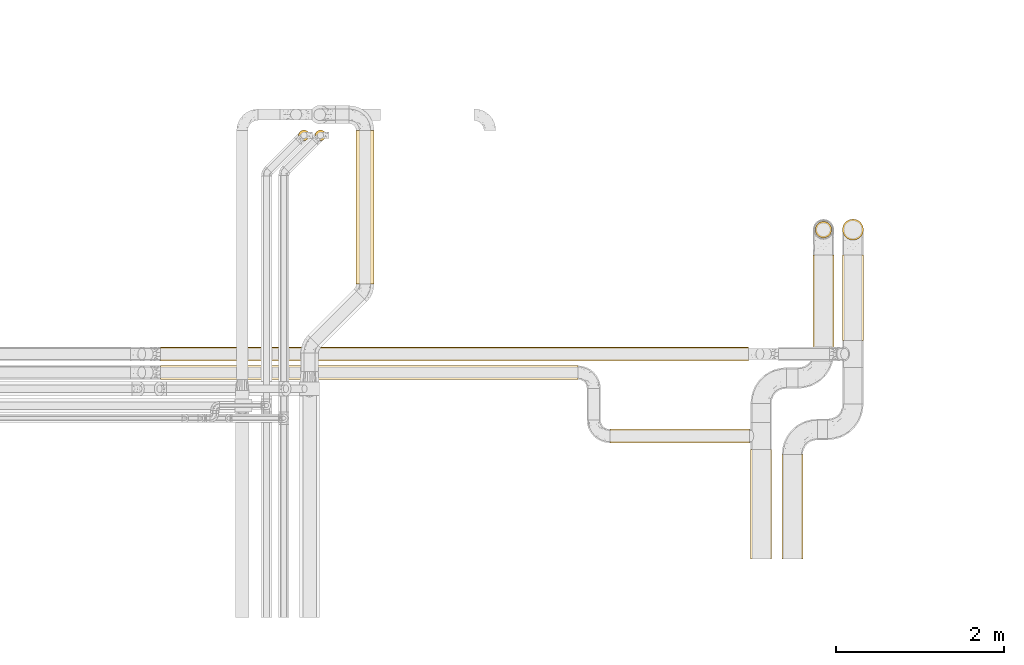
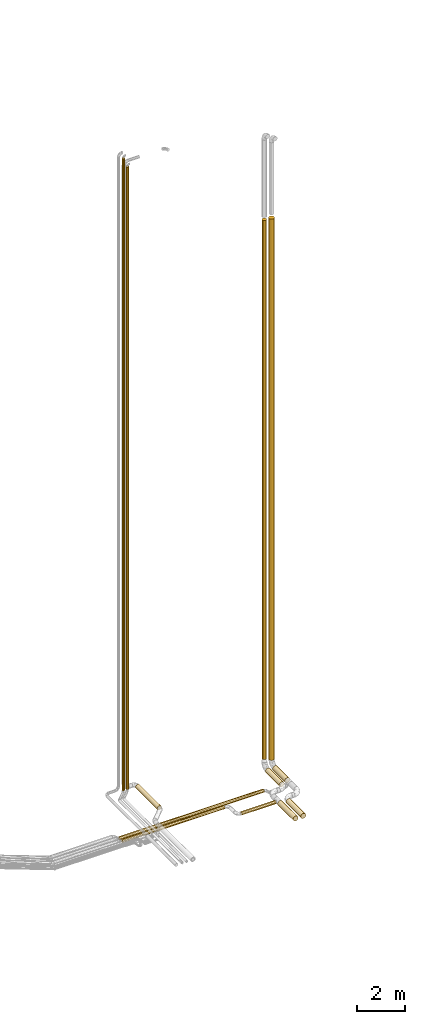
# One storey, part 2 of 93: 12 coverings.
"""IFC2X3 building model written with IfcOpenShell, lengths in millimetres."""

from ifc_helpers import new_model, entity, si_unit, converted_unit, derived_unit, direction, frame, origin, origin_2d_with_axis, place, context, subcontext, project, spatial, circle, extrude, element, save


model = new_model("IFC2X3")

# Units and contexts
model_context = context("Model", 3, precision=0.01, world=origin(), true_north=direction((6.12303176911189e-17, 1.0)))
body_context = subcontext(model_context, "Body", "Model", "MODEL_VIEW")
ifc_project = project(units=[si_unit("LENGTHUNIT", "METRE", prefix="MILLI"), si_unit("AREAUNIT", "SQUARE_METRE"), si_unit("VOLUMEUNIT", "CUBIC_METRE"), converted_unit("PLANEANGLEUNIT", "DEGREE", entity("IfcRatioMeasure", 0.0174532925199433), si_unit("PLANEANGLEUNIT", "RADIAN"), dimensions=[0, 0, 0, 0, 0, 0, 0]), si_unit("MASSUNIT", "GRAM", prefix="KILO"), derived_unit("MASSDENSITYUNIT", [(si_unit("MASSUNIT", "GRAM", prefix="KILO"), 1), (si_unit("LENGTHUNIT", "METRE"), -3)]), derived_unit("MOMENTOFINERTIAUNIT", [(si_unit("LENGTHUNIT", "METRE"), 4)]), si_unit("TIMEUNIT", "SECOND"), si_unit("FREQUENCYUNIT", "HERTZ"), si_unit("THERMODYNAMICTEMPERATUREUNIT", "DEGREE_CELSIUS"), derived_unit("THERMALTRANSMITTANCEUNIT", [(si_unit("MASSUNIT", "GRAM", prefix="KILO"), 1), (si_unit("THERMODYNAMICTEMPERATUREUNIT", "KELVIN"), -1), (si_unit("TIMEUNIT", "SECOND"), -3)]), derived_unit("VOLUMETRICFLOWRATEUNIT", [(si_unit("LENGTHUNIT", "METRE"), 3), (si_unit("TIMEUNIT", "SECOND"), -1)]), derived_unit("MASSFLOWRATEUNIT", [(si_unit("MASSUNIT", "GRAM", prefix="KILO"), 1), (si_unit("TIMEUNIT", "SECOND"), -1)]), derived_unit("ROTATIONALFREQUENCYUNIT", [(si_unit("TIMEUNIT", "SECOND"), -1)]), si_unit("ELECTRICCURRENTUNIT", "AMPERE"), si_unit("ELECTRICVOLTAGEUNIT", "VOLT"), si_unit("POWERUNIT", "WATT"), si_unit("FORCEUNIT", "NEWTON", prefix="KILO"), si_unit("ILLUMINANCEUNIT", "LUX"), si_unit("LUMINOUSFLUXUNIT", "LUMEN"), si_unit("LUMINOUSINTENSITYUNIT", "CANDELA"), derived_unit("USERDEFINED", [(si_unit("MASSUNIT", "GRAM", prefix="KILO"), -1), (si_unit("LENGTHUNIT", "METRE"), -2), (si_unit("TIMEUNIT", "SECOND"), 3), (si_unit("LUMINOUSFLUXUNIT", "LUMEN"), 1)]), derived_unit("LINEARVELOCITYUNIT", [(si_unit("LENGTHUNIT", "METRE"), 1), (si_unit("TIMEUNIT", "SECOND"), -1)]), si_unit("PRESSUREUNIT", "PASCAL"), derived_unit("USERDEFINED", [(si_unit("LENGTHUNIT", "METRE"), -2), (si_unit("MASSUNIT", "GRAM", prefix="KILO"), 1), (si_unit("TIMEUNIT", "SECOND"), -2)]), derived_unit("LINEARFORCEUNIT", [(si_unit("MASSUNIT", "GRAM", prefix="KILO"), 1), (si_unit("LENGTHUNIT", "METRE"), 1), (si_unit("TIMEUNIT", "SECOND"), -2), (si_unit("LENGTHUNIT", "METRE"), -1)]), derived_unit("PLANARFORCEUNIT", [(si_unit("MASSUNIT", "GRAM", prefix="KILO"), 1), (si_unit("LENGTHUNIT", "METRE"), 1), (si_unit("TIMEUNIT", "SECOND"), -2), (si_unit("LENGTHUNIT", "METRE"), -2)])], contexts=[model_context])

# Site, building, storey
site_placement = place(None, origin())
site = spatial("IfcSite", under=ifc_project, at=site_placement, CompositionType="ELEMENT")
building_placement = place(site_placement, origin())
building = spatial("IfcBuilding", under=site, at=building_placement, CompositionType="ELEMENT")
storey_placement = place(building_placement, frame((0.0, 0.0, -4200.0)))
storey = spatial("IfcBuildingStorey", under=building, at=storey_placement, CompositionType="ELEMENT", Elevation=-4200.0)

# Coverings
covering_1_placement = place(storey_placement, frame((25531.03, 10304.27, 2891.9)))
element("IfcCovering", 1, at=covering_1_placement, inside=storey, PredefinedType="INSULATION", context=body_context, shape_type="SweptSolid", body=[
    extrude(circle(Radius=106.5, at=origin_2d_with_axis()), frame((108.1, 0.0, 108.1), z_axis=(0.0, 1.0, 0.0), x_axis=(-1.0, 0.0, 0.0)), (0.0, 0.0, 1.0), 1821.29942314912),
])
covering_2_placement = place(storey_placement, frame((30213.69, 7038.76, 2673.9)))
element("IfcCovering", 2, at=covering_2_placement, inside=storey, PredefinedType="INSULATION", context=body_context, shape_type="SweptSolid", body=[
    extrude(circle(Radius=124.5, at=origin_2d_with_axis()), frame((126.1, 0.0, 126.1), z_axis=(0.0, 1.0, 0.0), x_axis=(-1.0, 0.0, 0.0)), (0.0, 0.0, 1.0), 1301.23958365229),
])
covering_3_placement = place(storey_placement, frame((30980.9, 10850.9, 3240.0)))
element("IfcCovering", 3, at=covering_3_placement, inside=storey, PredefinedType="INSULATION", context=body_context, shape_type="SweptSolid", body=[
    extrude(circle(Radius=97.5, at=origin_2d_with_axis()), frame((99.1, 99.1, 0.0), z_axis=(0.0, 0.0, 1.0), x_axis=(-1.0, 0.0, 0.0)), (0.0, 0.0, 1.0), 27542.5),
])
covering_4_placement = place(storey_placement, frame((24847.71, 12005.41, 3100.0)))
element("IfcCovering", 4, at=covering_4_placement, inside=storey, PredefinedType="INSULATION", context=body_context, shape_type="SweptSolid", body=[
    extrude(circle(Radius=63.0, at=origin_2d_with_axis()), frame((64.6, 64.6, 0.0), z_axis=(0.0, 0.0, 1.0), x_axis=(-1.0, 0.0, 0.0)), (0.0, 0.0, 1.0), 32300.0),
])
covering_5_placement = place(storey_placement, frame((25044.13, 12005.41, 3100.0)))
element("IfcCovering", 5, at=covering_5_placement, inside=storey, PredefinedType="INSULATION", context=body_context, shape_type="SweptSolid", body=[
    extrude(circle(Radius=63.0, at=origin_2d_with_axis()), frame((64.6, 64.6, 0.0), z_axis=(0.0, 0.0, 1.0), x_axis=(-1.0, 0.0, 0.0)), (0.0, 0.0, 1.0), 31800.0),
])
covering_6_placement = place(storey_placement, frame((30583.69, 7038.76, 2673.9)))
element("IfcCovering", 6, at=covering_6_placement, inside=storey, PredefinedType="INSULATION", context=body_context, shape_type="SweptSolid", body=[
    extrude(circle(Radius=124.5, at=origin_2d_with_axis()), frame((126.1, 0.0, 126.1), z_axis=(0.0, 1.0, 0.0), x_axis=(-1.0, 0.0, 0.0)), (0.0, 0.0, 1.0), 1239.99999999999),
])
covering_7_placement = place(storey_placement, frame((31303.9, 9634.14, 2673.9)))
element("IfcCovering", 7, at=covering_7_placement, inside=storey, PredefinedType="INSULATION", context=body_context, shape_type="SweptSolid", body=[
    extrude(circle(Radius=124.5, at=origin_2d_with_axis()), frame((126.1, 0.0, 126.1), z_axis=(0.0, 1.0, 0.0), x_axis=(0.707106781186549, 0.0, -0.707106781186546)), (0.0, 0.0, 1.0), 1015.8612780823),
])
covering_8_placement = place(storey_placement, frame((31303.9, 10823.9, 3100.0)))
element("IfcCovering", 8, at=covering_8_placement, inside=storey, PredefinedType="INSULATION", context=body_context, shape_type="SweptSolid", body=[
    extrude(circle(Radius=124.5, at=origin_2d_with_axis()), frame((126.1, 126.1, 0.0)), (0.0, 0.0, 1.0), 27657.5),
])
covering_9_placement = place(storey_placement, frame((23210.57, 9391.04, 2716.9)))
element("IfcCovering", 9, at=covering_9_placement, inside=storey, PredefinedType="INSULATION", context=body_context, shape_type="SweptSolid", body=[
    extrude(circle(Radius=81.5, at=origin_2d_with_axis()), frame((0.0, 83.1, 83.1), z_axis=(1.0, 0.0, 0.0), x_axis=(0.0, 1.0, 0.0)), (0.0, 0.0, 1.0), 6980.73067498007),
])
covering_10_placement = place(storey_placement, frame((23210.57, 9171.64, 2716.9)))
element("IfcCovering", 10, at=covering_10_placement, inside=storey, PredefinedType="INSULATION", context=body_context, shape_type="SweptSolid", body=[
    extrude(circle(Radius=81.5, at=origin_2d_with_axis()), frame((0.0, 83.1, 83.1), z_axis=(1.0, 0.0, 0.0), x_axis=(0.0, -1.0, 0.0)), (0.0, 0.0, 1.0), 4952.83139254912),
])
covering_11_placement = place(storey_placement, frame((28543.4, 8416.9, 2716.9)))
element("IfcCovering", 11, at=covering_11_placement, inside=storey, PredefinedType="INSULATION", context=body_context, shape_type="SweptSolid", body=[
    extrude(circle(Radius=81.5, at=origin_2d_with_axis()), frame((0.0, 83.1, 83.1), z_axis=(1.0, 0.0, 0.0), x_axis=(0.0, 1.0, 0.0)), (0.0, 0.0, 1.0), 1656.38155763209),
])
covering_12_placement = place(storey_placement, frame((30953.9, 9488.76, 2673.9)))
element("IfcCovering", 12, at=covering_12_placement, inside=storey, PredefinedType="INSULATION", context=body_context, shape_type="SweptSolid", body=[
    extrude(circle(Radius=124.5, at=origin_2d_with_axis()), frame((126.1, 0.0, 126.1), z_axis=(0.0, 1.0, 0.0), x_axis=(-1.0, 0.0, 0.0)), (0.0, 0.0, 1.0), 1161.23991781962),
])

save(model, "model.ifc")
